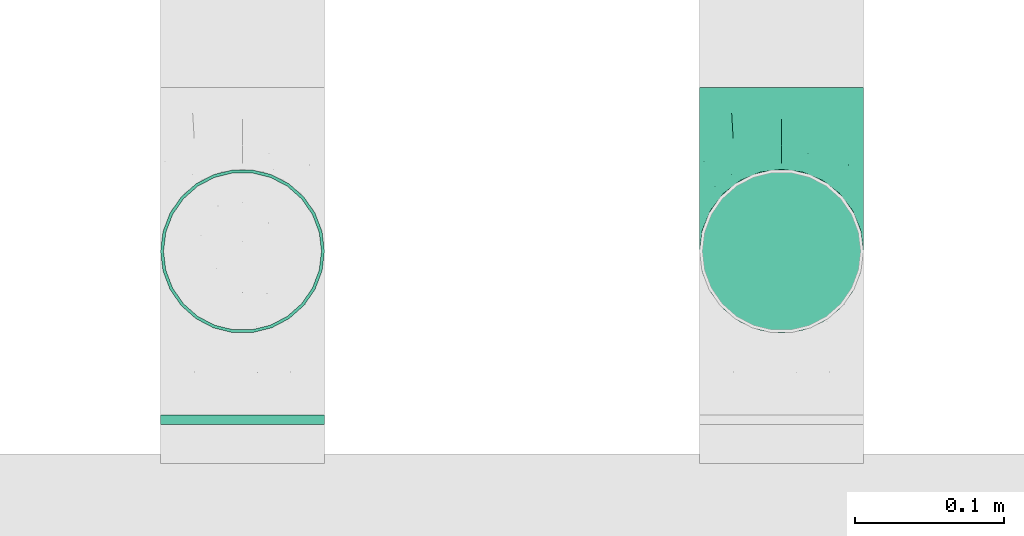
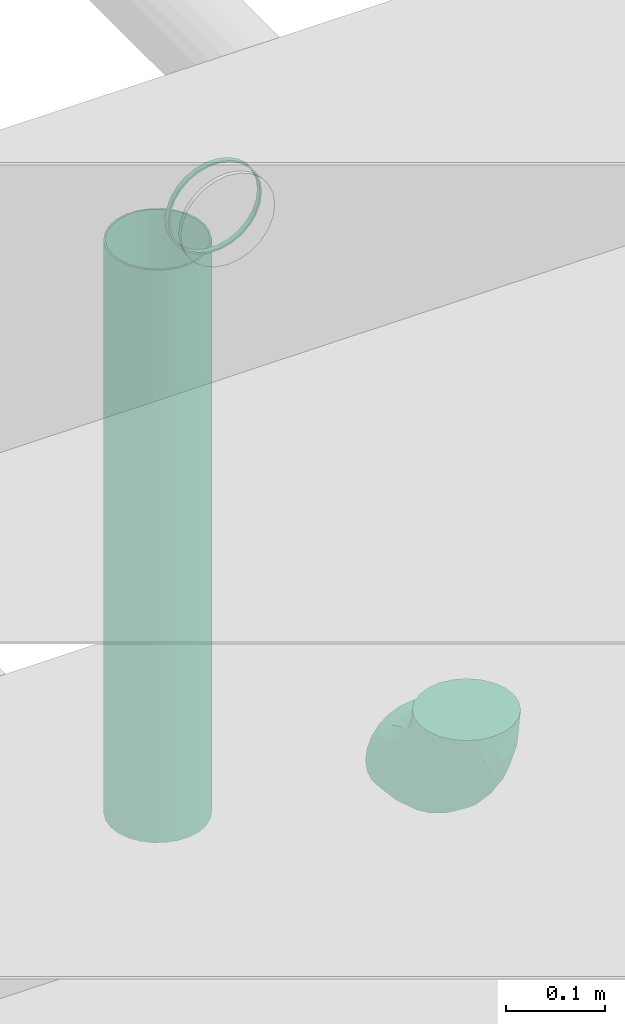
# One storey, part 49 of 91: 2 flow segments, 1 flow fitting.
"""IFC2X3 building model written with IfcOpenShell, lengths in millimetres."""

from ifc_helpers import new_model, entity, si_unit, converted_unit, derived_unit, direction, frame, origin_with_axes, origin_2d_with_axis, place, context, subcontext, project, spatial, hollow_circle, extrude, open_shell, surface_model, source, transform, mapped, material, layer, layer_set, layer_usage, type_object, element, save


model = new_model("IFC2X3")

# Units and contexts
model_context = context("Model", 3, precision=1e-05, world=origin_with_axes(), true_north=direction((0.0, 1.0)))
body_context = subcontext(model_context, "Body", "Model", "MODEL_VIEW")
ifc_project = project(units=[si_unit("AREAUNIT", "SQUARE_METRE"), si_unit("VOLUMEUNIT", "CUBIC_METRE", prefix="DECI"), si_unit("TIMEUNIT", "SECOND"), si_unit("THERMODYNAMICTEMPERATUREUNIT", "DEGREE_CELSIUS"), si_unit("PRESSUREUNIT", "PASCAL"), si_unit("MASSUNIT", "GRAM", prefix="KILO"), si_unit("LENGTHUNIT", "METRE", prefix="MILLI"), si_unit("POWERUNIT", "WATT"), si_unit("ELECTRICCURRENTUNIT", "AMPERE"), si_unit("ELECTRICVOLTAGEUNIT", "VOLT"), derived_unit("VOLUMETRICFLOWRATEUNIT", [(si_unit("VOLUMEUNIT", "CUBIC_METRE", prefix="DECI"), 1), (si_unit("TIMEUNIT", "SECOND"), -1)]), derived_unit("LINEARVELOCITYUNIT", [(si_unit("LENGTHUNIT", "METRE"), 1), (si_unit("TIMEUNIT", "SECOND"), -1)]), derived_unit("MASSDENSITYUNIT", [(si_unit("MASSUNIT", "GRAM", prefix="KILO"), 1), (si_unit("VOLUMEUNIT", "CUBIC_METRE"), -1)]), converted_unit("PLANEANGLEUNIT", "DEGREE", entity("IfcRatioMeasure", 0.01745), si_unit("PLANEANGLEUNIT", "RADIAN"), dimensions=[0, 0, 0, 0, 0, 0, 0])], contexts=[model_context])

# Site, building, storey
site_placement = place(None, origin_with_axes())
site = spatial("IfcSite", under=ifc_project, at=site_placement, CompositionType="ELEMENT")
building_placement = place(site_placement, origin_with_axes())
building = spatial("IfcBuilding", under=site, at=building_placement, Name="mc-building", CompositionType="ELEMENT")
storey_placement = place(building_placement, frame((0.0, 0.0, 8700.0), z_axis=(0.0, 0.0, 1.0), x_axis=(1.0, 0.0, 0.0)))
storey = spatial("IfcBuildingStorey", under=building, at=storey_placement, CompositionType="ELEMENT", Elevation=8700.0)

# Flow segment
ifc_material = material(Name="FZ1")
ifc_layer = layer(ifc_material, 0.0)
ifc_layer_set = layer_set([ifc_layer], Name="FZ1")
ifc_layer_usage = layer_usage(ifc_layer_set, "AXIS1", "POSITIVE", 0.0)
duct_segment_type = type_object("IfcDuctSegmentType", PredefinedType="RIGIDSEGMENT")
shared_shape_1 = source(origin_with_axes(), body_context, "Body", "SweptSolid", [
    extrude(hollow_circle(Radius=55.0, WallThickness=2.0, at=origin_2d_with_axis()), frame((0.0, 0.0, 0.0), z_axis=(1.0, 0.0, 0.0), x_axis=(0.0, 1.0, 0.0)), (0.0, 0.0, 1.0), 709.0),
])
flow_segment_1_placement = place(storey_placement, frame((18242.77608, 8426.54565, 1234.0), z_axis=(0.0, 1.0, 0.0), x_axis=(0.0, 0.0, -1.0)))
element("IfcFlowSegment", 1, at=flow_segment_1_placement, inside=storey, type_object=duct_segment_type, material=ifc_layer_usage, context=body_context, shape_type="MappedRepresentation", body=[
    mapped(shared_shape_1, transform((0.0, 0.0, 0.0), scale=1.0)),
])

# Flow fitting
duct_fitting_type = type_object("IfcDuctFittingType", Name="BU", PredefinedType="BEND")
shared_shape_2 = source(origin_with_axes(), body_context, "Body", "SurfaceModel", [
    surface_model("IfcShellBasedSurfaceModel", [(-110.0, 0.0, -55.0), (-110.0, -14.23505, -53.12592), (-110.0, 14.23505, -53.12592), (-110.0, 53.12592, 14.23505), (-110.0, 27.5, -47.63139), (-110.0, 38.89087, -38.89087), (-110.0, -55.0, 0.0), (-110.0, -53.12592, 14.23505), (-110.0, -38.89087, -38.89087), (-110.0, -27.5, -47.63139), (-110.0, -53.12592, -14.23505), (-110.0, -47.63139, -27.5), (-110.0, -14.23505, 53.12592), (-110.0, 14.23505, 53.12592), (-110.0, 27.5, 47.63139), (-110.0, -47.63139, 27.5), (-110.0, -38.89087, 38.89087), (-110.0, -27.5, 47.63139), (-110.0, 0.0, 55.0), (-110.0, 55.0, 0.0), (-110.0, 53.12592, -14.23505), (-110.0, 47.63139, -27.5), (-110.0, 47.63139, 27.5), (-110.0, 38.89087, 38.89087), (-14.23505, 110.0, -53.12592), (-55.0, 110.0, 0.0), (0.0, 110.0, -55.0), (-27.5, 110.0, -47.63139), (-38.89087, 110.0, -38.89087), (-47.63139, 110.0, -27.5), (38.89087, 110.0, -38.89087), (53.12592, 110.0, 14.23505), (27.5, 110.0, -47.63139), (14.23505, 110.0, -53.12592), (47.63139, 110.0, -27.5), (53.12592, 110.0, -14.23505), (55.0, 110.0, 0.0), (-53.12592, 110.0, -14.23505), (-53.12592, 110.0, 14.23505), (-47.63139, 110.0, 27.5), (-38.89087, 110.0, 38.89087), (-27.5, 110.0, 47.63139), (0.0, 110.0, 55.0), (-14.23505, 110.0, 53.12592), (38.89087, 110.0, 38.89087), (47.63139, 110.0, 27.5), (27.5, 110.0, 47.63139), (14.23505, 110.0, 53.12592), (-64.21732, 48.68956, 43.63444), (-76.6405, 38.18013, 45.55988), (-60.44912, 32.56953, 51.94617), (-76.00813, 5.38378, 55.0), (-90.15553, 11.94394, 54.09138), (-78.5998, 26.77405, 50.81338), (-70.18771, 18.55163, 54.03432), (-75.55424, 54.2118, 32.41257), (-93.27622, 45.77614, 33.48188), (-96.12334, 22.13664, 50.81337), (-21.00813, 45.34362, 55.0), (-18.36258, 70.48427, 54.04484), (-32.04182, 59.64019, 52.24446), (-63.88653, 74.77858, 17.99134), (-74.66383, 63.08407, 19.92123), (-63.60674, 66.07878, 29.97482), (-99.597, 52.72185, 18.52927), (-93.11138, 56.59448, 10.50359), (-98.21577, 57.34403, 0.0), (-53.42855, 92.60092, 21.04759), (-88.54852, 54.8376, 21.04759), (-11.86161, 90.23965, 54.10313), (-5.38378, 76.00813, 55.0), (-57.34403, 98.21577, 0.0), (-56.64619, 93.12774, 10.22088), (-45.34362, 21.00813, 55.0), (-44.60838, 44.60838, 52.13415), (-92.68484, 35.46673, 43.63443), (-22.25266, 95.40765, 50.81337), (-35.97783, 90.61597, 43.63443), (-43.70931, 69.58671, 44.47149), (-27.23711, 77.39884, 50.81337), (-57.2828, 79.3123, 24.9774), (-58.67786, 84.31125, 16.04456), (-82.93277, 60.36161, 12.91784), (-49.88337, 54.51816, 47.224), (-74.57753, 66.83759, 9.55742), (-45.35812, 94.97281, 33.48188), (-59.18663, 88.95241, 0.0), (-51.517, 78.6292, 33.48188), (-65.14788, 80.03077, 0.0), (-56.45322, 62.06476, 39.63545), (-88.95241, 59.18663, 0.0), (-71.10913, 71.10913, 0.0), (-80.03077, 65.14788, 0.0), (-94.9309, 45.36788, -33.48188), (-93.11358, 56.60141, -10.46614), (-99.64997, 52.79499, -18.30015), (-90.20425, 36.08686, -43.63443), (-79.99933, 46.56772, -37.92748), (-76.00813, 5.38378, -55.0), (-72.75364, 19.68651, -53.60527), (-45.34362, 21.00813, -55.0), (-21.91957, 65.12078, -53.85897), (-5.38378, 76.00813, -55.0), (-21.00813, 45.34362, -55.0), (-35.41876, 92.89265, -43.63443), (-91.10309, 11.02766, -54.21832), (-45.77614, 93.27622, -33.48188), (-90.50474, 23.21022, -50.81337), (-70.92854, 33.31794, -49.51754), (-78.52933, 63.35627, -11.73997), (-24.91508, 84.05606, -50.81337), (-88.78941, 54.74452, -21.04759), (-69.59921, 57.34866, -33.48187), (-73.36422, 62.46673, -22.94182), (-63.49062, 67.59111, -28.46929), (-56.59448, 93.11138, -10.50359), (-54.8376, 88.54852, -21.04759), (-54.10679, 75.85581, -32.31867), (-57.75956, 31.09612, -52.80882), (-52.72185, 99.597, -18.52927), (-12.62913, 89.46304, -53.99097), (-34.46825, 66.46123, -50.04329), (-43.9837, 43.9837, -52.42279), (-65.78527, 72.58348, -17.68796), (-70.34468, 43.65295, -44.21951), (-57.47001, 51.99467, -44.91465), (-60.72547, 82.29174, -12.88567), (-42.34915, 74.24548, -43.63444), (-57.25194, 63.5016, -38.08211), (-80.95344, 53.56991, -29.32027), (-52.32891, 4.55257, -54.0482), (32.52942, 47.13398, -30.48571), (14.88266, 20.92917, -33.7947), (14.95561, 36.05775, -42.26543), (30.24048, 70.09027, -41.7461), (19.3559, 65.35825, -48.00507), (-70.35075, -46.44478, -19.5952), (-47.13398, -32.52942, -30.48571), (-28.49299, -30.5778, -16.4009), (-4.55257, 52.32891, -54.0482), (-22.4954, 22.4954, -53.25347), (-75.47368, -11.22546, -52.60718), (-81.32209, -51.5606, -9.98467), (-80.81763, -41.84862, -32.14655), (-70.09027, -30.24048, -41.7461), (-36.05774, -14.95561, -42.26543), (-9.15831, -10.852, -27.8997), (-65.35825, -19.3559, -48.00507), (11.22546, 75.47368, -52.60718), (3.94376, 43.9333, -50.53315), (-13.39742, 13.39743, -48.13058), (-43.9333, -3.94376, -50.53315), (49.37776, 67.29486, 0.0), (41.8609, 47.82256, -9.92641), (50.20582, 74.51695, -9.9731), (18.93131, 11.7156, -17.56239), (-27.5, -32.89419, 0.0), (-1.23348, -12.25375, -12.18106), (41.84862, 80.81763, -32.14655), (35.70604, 41.31408, -20.38235), (46.44478, 70.35075, -19.5952), (32.89419, 27.5, 0.0), (6.67262, -6.67262, 0.0), (-67.29486, -49.37776, 0.0), (-50.36265, -42.95545, -9.51562), (-5.47251, 5.47251, -39.92906), (-70.35075, -46.44478, 19.5952), (-74.51695, -50.20582, 9.9731), (-41.31407, -35.70604, 20.38235), (-47.13398, -32.52942, 30.48571), (-80.81763, -41.84862, 32.14655), (-4.55257, 52.32891, 54.0482), (11.22546, 75.47368, 52.60718), (-43.9333, -3.94376, 50.53315), (-65.35825, -19.3559, 48.00507), (-36.05774, -14.95561, 42.26543), (-70.09027, -30.24048, 41.7461), (-11.7156, -18.93131, 17.56239), (30.5778, 28.49299, 16.4009), (12.25375, 1.23348, 12.18106), (51.5606, 81.32209, 9.98467), (42.95545, 50.36265, 9.51562), (-75.47368, -11.22546, 52.60718), (-52.32891, 4.55257, 54.0482), (3.94376, 43.9333, 50.53315), (-22.4954, 22.4954, 53.25347), (-13.39742, 13.39743, 48.13058), (10.852, 9.15831, 27.8997), (-20.92916, -14.88266, 33.79469), (-47.82256, -41.8609, 9.92641), (32.52942, 47.13398, 30.48571), (46.44478, 70.35075, 19.5952), (41.84862, 80.81763, 32.14655), (30.24048, 70.09027, 41.7461), (19.3559, 65.35825, 48.00507), (14.95561, 36.05775, 42.26543), (-5.47251, 5.47251, 39.92906)], [open_shell([[[0, 1, 2]], [[2, 3, 4]], [[4, 3, 5]], [[2, 6, 7]], [[8, 6, 9]], [[1, 9, 6]], [[10, 6, 11]], [[8, 11, 6]], [[6, 2, 1]], [[12, 13, 14]], [[15, 2, 7]], [[16, 17, 2]], [[2, 17, 12]], [[12, 18, 13]], [[19, 20, 3]], [[5, 3, 21]], [[20, 21, 3]], [[22, 3, 2]], [[23, 22, 2]], [[12, 14, 2]], [[2, 14, 23]], [[15, 16, 2]], [[24, 25, 26]], [[27, 25, 24]], [[25, 28, 29]], [[28, 25, 27]], [[30, 26, 31]], [[26, 30, 32]], [[32, 33, 26]], [[34, 31, 35]], [[31, 34, 30]], [[35, 31, 36]], [[29, 37, 25]], [[38, 39, 26]], [[39, 40, 26]], [[41, 42, 40]], [[42, 26, 40]], [[42, 41, 43]], [[26, 44, 45]], [[31, 26, 45]], [[26, 46, 44]], [[47, 46, 26]], [[42, 47, 26]], [[25, 38, 26]], [[48, 49, 50]], [[18, 51, 52]], [[53, 54, 50]], [[55, 56, 49]], [[56, 22, 23]], [[13, 57, 14]], [[58, 59, 60]], [[61, 62, 63]], [[3, 64, 65]], [[53, 52, 54]], [[3, 65, 66]], [[67, 39, 38]], [[56, 68, 64]], [[65, 64, 68]], [[69, 59, 70]], [[38, 71, 72]], [[73, 58, 74]], [[75, 49, 56]], [[76, 69, 43]], [[53, 57, 52]], [[77, 78, 79]], [[41, 76, 43]], [[43, 69, 42]], [[55, 68, 56]], [[23, 14, 75]], [[76, 77, 79]], [[80, 67, 81]], [[62, 82, 68]], [[60, 78, 83]], [[62, 84, 82]], [[85, 77, 40]], [[81, 67, 72]], [[86, 72, 71]], [[87, 85, 67]], [[61, 81, 88]], [[77, 41, 40]], [[78, 77, 87]], [[23, 75, 56]], [[83, 89, 48]], [[85, 40, 39]], [[62, 68, 55]], [[89, 87, 63]], [[83, 48, 50]], [[57, 75, 14]], [[49, 75, 53]], [[67, 85, 39]], [[87, 77, 85]], [[63, 62, 55]], [[89, 55, 48]], [[80, 63, 87]], [[66, 65, 90]], [[66, 19, 3]], [[84, 91, 92]], [[92, 90, 82]], [[65, 82, 90]], [[61, 84, 62]], [[92, 82, 84]], [[68, 82, 65]], [[3, 22, 64]], [[56, 64, 22]], [[38, 25, 71]], [[81, 72, 86]], [[38, 72, 67]], [[91, 61, 88]], [[80, 81, 61]], [[63, 80, 61]], [[67, 80, 87]], [[77, 76, 41]], [[79, 59, 69]], [[79, 69, 76]], [[42, 69, 70]], [[60, 59, 79]], [[58, 70, 59]], [[78, 60, 79]], [[58, 60, 74]], [[52, 57, 13]], [[75, 57, 53]], [[18, 52, 13]], [[52, 51, 54]], [[51, 73, 54]], [[50, 73, 74]], [[73, 50, 54]], [[50, 74, 83]], [[60, 83, 74]], [[89, 83, 78]], [[87, 89, 78]], [[55, 89, 63]], [[50, 49, 53]], [[55, 49, 48]], [[81, 86, 88]], [[91, 84, 61]], [[5, 21, 93]], [[90, 94, 66]], [[20, 94, 95]], [[96, 93, 97]], [[98, 99, 100]], [[96, 4, 5]], [[101, 102, 103]], [[28, 27, 104]], [[2, 105, 0]], [[104, 106, 28]], [[99, 105, 107]], [[108, 107, 96]], [[90, 109, 94]], [[107, 2, 4]], [[20, 66, 94]], [[27, 24, 110]], [[109, 111, 94]], [[112, 113, 114]], [[37, 115, 71]], [[116, 106, 117]], [[99, 118, 100]], [[116, 115, 119]], [[37, 119, 115]], [[24, 120, 110]], [[121, 110, 101]], [[119, 106, 116]], [[101, 110, 120]], [[122, 103, 100]], [[117, 123, 116]], [[124, 125, 108]], [[115, 116, 126]], [[106, 29, 28]], [[26, 102, 120]], [[127, 104, 110]], [[97, 124, 96]], [[125, 122, 118]], [[128, 127, 125]], [[96, 5, 93]], [[115, 126, 86]], [[117, 106, 127]], [[111, 113, 129]], [[95, 93, 21]], [[97, 129, 112]], [[110, 104, 27]], [[106, 104, 127]], [[96, 107, 4]], [[99, 107, 108]], [[99, 108, 118]], [[105, 99, 98]], [[112, 114, 128]], [[121, 125, 127]], [[20, 19, 66]], [[109, 90, 92]], [[94, 111, 95]], [[91, 123, 109]], [[129, 113, 112]], [[93, 95, 111]], [[21, 20, 95]], [[71, 115, 86]], [[71, 25, 37]], [[123, 91, 88]], [[126, 116, 123]], [[123, 88, 126]], [[86, 126, 88]], [[37, 29, 119]], [[106, 119, 29]], [[129, 93, 111]], [[124, 112, 125]], [[0, 105, 98]], [[107, 105, 2]], [[125, 118, 108]], [[100, 118, 122]], [[93, 129, 97]], [[113, 111, 109]], [[109, 123, 113]], [[114, 123, 117]], [[123, 114, 113]], [[128, 114, 117]], [[127, 128, 117]], [[112, 128, 125]], [[103, 122, 101]], [[110, 121, 127]], [[101, 122, 121]], [[125, 121, 122]], [[26, 120, 24]], [[101, 120, 102]], [[96, 124, 108]], [[92, 91, 109]], [[112, 124, 97]], [[100, 130, 98]], [[131, 132, 133]], [[32, 134, 135]], [[136, 137, 138]], [[139, 140, 103]], [[98, 141, 0]], [[142, 10, 136]], [[143, 144, 137]], [[6, 10, 142]], [[137, 145, 146]], [[144, 147, 145]], [[143, 136, 11]], [[11, 136, 10]], [[8, 143, 11]], [[148, 149, 139]], [[8, 9, 144]], [[9, 1, 147]], [[130, 141, 98]], [[103, 140, 100]], [[148, 135, 149]], [[150, 151, 140]], [[152, 153, 154]], [[130, 140, 151]], [[148, 26, 33]], [[147, 1, 141]], [[155, 146, 132]], [[156, 138, 157]], [[134, 30, 158]], [[150, 140, 149]], [[158, 30, 34]], [[30, 134, 32]], [[153, 159, 160]], [[131, 160, 159]], [[144, 145, 137]], [[36, 152, 154]], [[146, 138, 137]], [[155, 161, 162]], [[158, 160, 131]], [[133, 149, 135]], [[156, 163, 164]], [[163, 142, 164]], [[139, 103, 102]], [[153, 152, 161]], [[34, 35, 160]], [[162, 157, 155]], [[132, 165, 133]], [[157, 146, 155]], [[140, 130, 100]], [[141, 130, 151]], [[141, 151, 147]], [[141, 1, 0]], [[102, 26, 148]], [[140, 139, 149]], [[102, 148, 139]], [[135, 33, 32]], [[151, 150, 145]], [[9, 147, 144]], [[151, 145, 147]], [[145, 165, 146]], [[135, 148, 33]], [[133, 135, 134]], [[131, 133, 134]], [[133, 165, 150]], [[133, 150, 149]], [[145, 150, 165]], [[132, 131, 159]], [[146, 165, 132]], [[160, 158, 34]], [[134, 158, 131]], [[144, 143, 8]], [[136, 143, 137]], [[155, 153, 161]], [[154, 153, 160]], [[153, 155, 159]], [[132, 159, 155]], [[160, 35, 154]], [[36, 154, 35]], [[164, 136, 138]], [[6, 142, 163]], [[136, 164, 142]], [[156, 164, 138]], [[156, 157, 162]], [[146, 157, 138]], [[15, 7, 166]], [[6, 163, 167]], [[168, 169, 166]], [[166, 169, 170]], [[171, 172, 70]], [[173, 174, 175]], [[17, 176, 174]], [[177, 156, 162]], [[176, 16, 170]], [[170, 16, 15]], [[161, 178, 179]], [[152, 180, 181]], [[182, 173, 183]], [[18, 12, 182]], [[184, 185, 186]], [[183, 185, 73]], [[183, 73, 51]], [[177, 187, 188]], [[189, 168, 166]], [[187, 178, 190]], [[16, 176, 17]], [[161, 152, 181]], [[45, 191, 31]], [[45, 44, 192]], [[192, 191, 45]], [[180, 36, 31]], [[193, 194, 195]], [[46, 47, 194]], [[193, 195, 190]], [[193, 44, 46]], [[172, 42, 70]], [[185, 58, 73]], [[189, 163, 156]], [[163, 189, 167]], [[70, 58, 171]], [[184, 171, 185]], [[169, 188, 175]], [[180, 31, 191]], [[192, 193, 190]], [[191, 190, 178]], [[182, 174, 173]], [[194, 47, 172]], [[190, 195, 187]], [[186, 185, 173]], [[162, 179, 177]], [[188, 196, 175]], [[179, 187, 177]], [[185, 171, 58]], [[172, 171, 184]], [[172, 184, 194]], [[172, 47, 42]], [[51, 18, 182]], [[185, 183, 173]], [[51, 182, 183]], [[174, 12, 17]], [[184, 186, 195]], [[46, 194, 193]], [[184, 195, 194]], [[195, 196, 187]], [[174, 182, 12]], [[175, 174, 176]], [[169, 175, 176]], [[175, 196, 186]], [[175, 186, 173]], [[195, 186, 196]], [[188, 169, 168]], [[187, 196, 188]], [[166, 170, 15]], [[176, 170, 169]], [[193, 192, 44]], [[191, 192, 190]], [[177, 189, 156]], [[167, 189, 166]], [[189, 177, 168]], [[188, 168, 177]], [[166, 7, 167]], [[6, 167, 7]], [[181, 191, 178]], [[36, 180, 152]], [[191, 181, 180]], [[161, 181, 178]], [[161, 179, 162]], [[187, 179, 178]]])]),
])
flow_fitting_placement = place(storey_placement, frame((18604.54349, 8426.54565, 415.0), z_axis=(-1.0, 0.0, 0.0), x_axis=(0.0, -1.0, 0.0)))
element("IfcFlowFitting", 2, at=flow_fitting_placement, inside=storey, type_object=duct_fitting_type, Name="BU", context=body_context, shape_type="MappedRepresentation", body=[
    mapped(shared_shape_2, transform((0.0, 0.0, 0.0), scale=1.0)),
])

# Flow segment
shared_shape_3 = source(origin_with_axes(), body_context, "Body", "SweptSolid", [
    extrude(hollow_circle(Radius=55.0, WallThickness=2.0, at=origin_2d_with_axis()), frame((0.0, 0.0, 0.0), z_axis=(1.0, 0.0, 0.0), x_axis=(0.0, 1.0, 0.0)), (0.0, 0.0, 1.0), 6.2),
])
flow_segment_2_placement = place(storey_placement, frame((18242.77608, 8310.34565, 1344.0), z_axis=(0.0, 0.0, 1.0), x_axis=(0.0, 1.0, 0.0)))
element("IfcFlowSegment", 3, at=flow_segment_2_placement, inside=storey, type_object=duct_segment_type, material=ifc_layer_usage, context=body_context, shape_type="MappedRepresentation", body=[
    mapped(shared_shape_3, transform((0.0, 0.0, 0.0), scale=1.0, scale2=1.0, scale3=1.0, uniform=False)),
])

save(model, "model.ifc")
